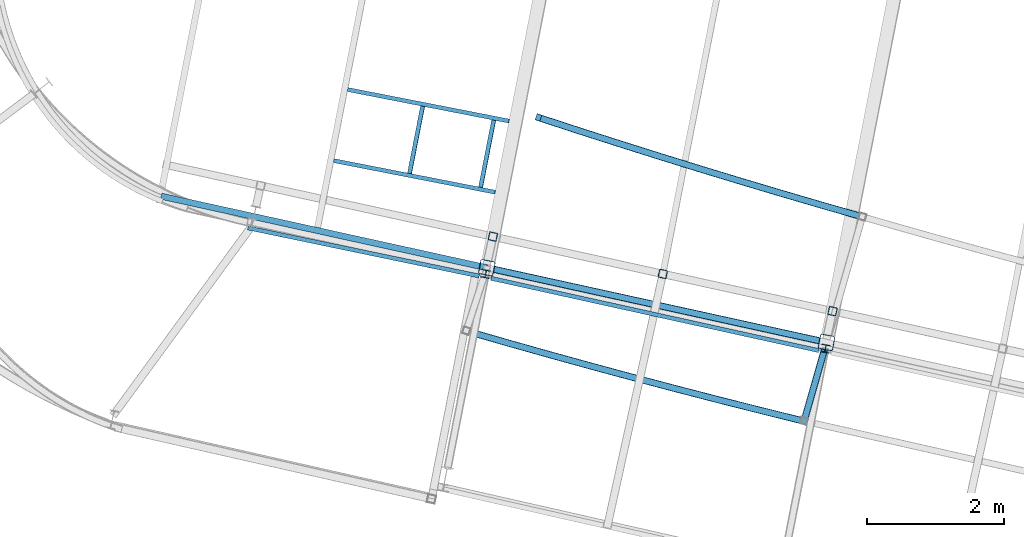
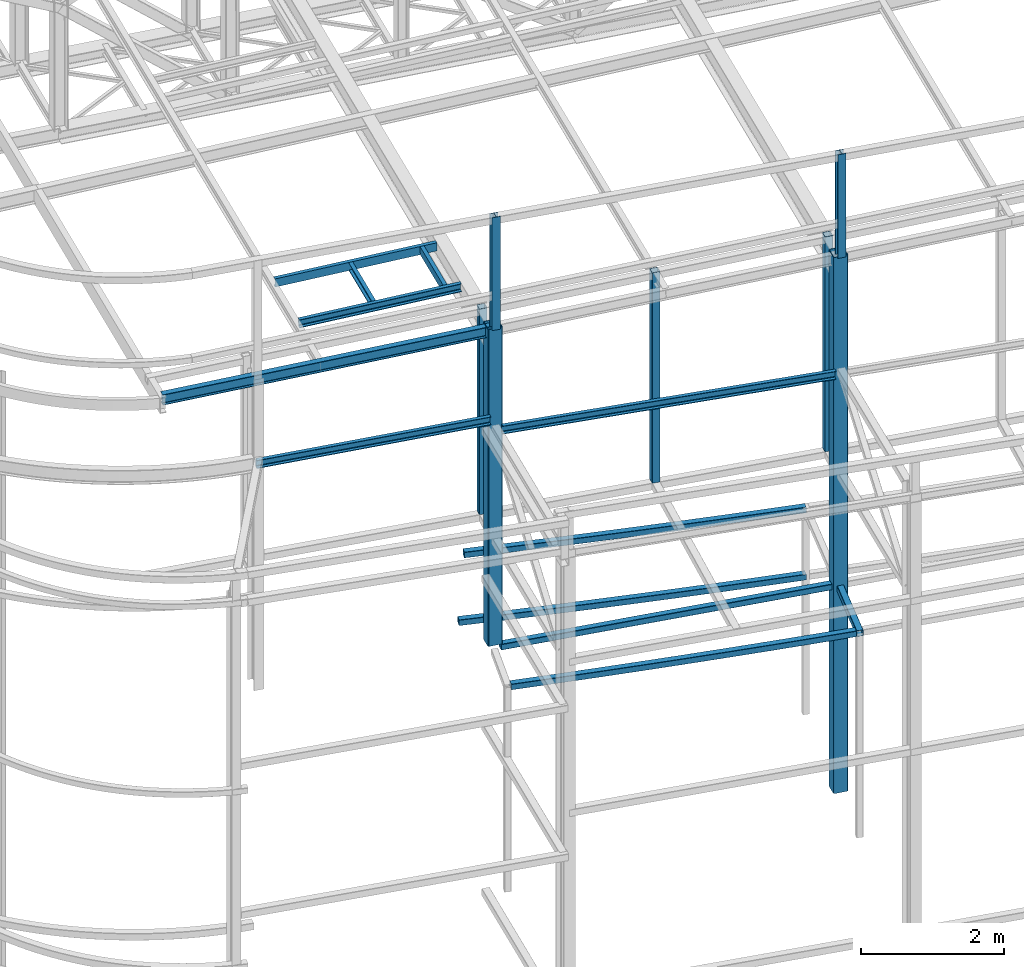
# One storey, part 22 of 215: 19 beams, 19 elements without a shape of their own.
"""IFC2X3 building model written with IfcOpenShell, lengths in millimetres."""

from ifc_helpers import new_model, entity, si_unit, frame, origin_with_axes, origin_2d_with_axis, place, context, subcontext, project, spatial, hollow_rectangle, i_section, u_section, extrude, clip, halfspace, material, type_object, element, aggregate, save


model = new_model("IFC2X3")

# Units and contexts
model_context = context("Model", 3, precision=1e-05, world=origin_with_axes())
body_context = subcontext(model_context, "Body", "Model", "MODEL_VIEW")
ifc_project = project(units=[si_unit("LENGTHUNIT", "METRE", prefix="MILLI"), si_unit("AREAUNIT", "SQUARE_METRE"), si_unit("VOLUMEUNIT", "CUBIC_METRE"), si_unit("MASSUNIT", "GRAM", prefix="KILO"), si_unit("TIMEUNIT", "SECOND"), si_unit("PLANEANGLEUNIT", "RADIAN"), si_unit("SOLIDANGLEUNIT", "STERADIAN"), si_unit("THERMODYNAMICTEMPERATUREUNIT", "DEGREE_CELSIUS"), si_unit("LUMINOUSINTENSITYUNIT", "LUMEN")], contexts=[model_context])

# Site, building, storey
site_placement = place(None, origin_with_axes())
site = spatial("IfcSite", under=ifc_project, at=site_placement, CompositionType="ELEMENT")
building_placement = place(site_placement, origin_with_axes())
building = spatial("IfcBuilding", under=site, at=building_placement, Name="Undefined", CompositionType="ELEMENT")
storey_placement = place(building_placement, origin_with_axes())
storey = spatial("IfcBuildingStorey", under=building, at=storey_placement, Name="Undefined", CompositionType="ELEMENT", Elevation=0.0)

# Assembly, beam
assembly_1_placement = place(storey_placement, origin_with_axes())
assembly_1 = element("IfcElementAssembly", 1, at=assembly_1_placement, inside=storey, Name="Steel Assembly", AssemblyPlace="NOTDEFINED", PredefinedType="RIGID_FRAME")
ifc_material_1 = material(Name="STEEL/S275JR")
beam_type_1 = type_object("IfcBeamType", PredefinedType="NOTDEFINED")
beam_1_placement = place(assembly_1_placement, frame((45837.825525202, 12378.7198330158, 6760.00000162277), z_axis=(0.29299903888334, 0.956112735619309, 0.0), x_axis=(0.95611273561931, -0.292999038883338, 0.0)))
beam_1 = element("IfcBeam", 2, at=beam_1_placement, type_object=beam_type_1, material=ifc_material_1, Name="POUTRE", context=body_context, shape_type="SweptSolid", body=[
    entity("IfcRevolvedAreaSolid", entity("IfcRectangleHollowProfileDef", "AREA", None, entity("IfcAxis2Placement2D", entity("IfcCartesianPoint", [0.0, 0.0]), entity("IfcDirection", [1.0, 0.0])), 100.0, 100.0, 4.0, 4.0, 8.0), entity("IfcAxis2Placement3D", entity("IfcCartesianPoint", [4921.58542662257, 0.0, 0.0]), entity("IfcDirection", [-0.999789717446947, 0.0, -0.0205066059442607]), entity("IfcDirection", [-6.93889390390723e-18, -1.0, -3.46944695195361e-18])), entity("IfcAxis1Placement", entity("IfcCartesianPoint", [0.0, 120000.0, 0.0]), entity("IfcDirection", [-1.0, 0.0, 0.0])), 0.0410160869179871),
])
aggregate(assembly_1, [beam_1])

assembly_2_placement = place(storey_placement, origin_with_axes())
assembly_2 = element("IfcElementAssembly", 3, at=assembly_2_placement, inside=storey, Name="Steel Assembly", AssemblyPlace="NOTDEFINED", PredefinedType="RIGID_FRAME")
beam_2_placement = place(assembly_2_placement, frame((45766.6930924765, 12402.1489431756, 5610.00000147687), z_axis=(0.293297378058425, 0.956021259190429, 0.0), x_axis=(0.95602125919043, -0.293297378058422, 0.0)))
beam_2 = element("IfcBeam", 4, at=beam_2_placement, type_object=beam_type_1, material=ifc_material_1, Name="POUTRE", context=body_context, shape_type="SweptSolid", body=[
    entity("IfcRevolvedAreaSolid", entity("IfcRectangleHollowProfileDef", "AREA", None, entity("IfcAxis2Placement2D", entity("IfcCartesianPoint", [0.0, 0.0]), entity("IfcDirection", [1.0, 0.0])), 100.0, 100.0, 4.0, 4.0, 8.0), entity("IfcAxis2Placement3D", entity("IfcCartesianPoint", [4996.46100115573, 0.0, 2.77359302256237e-13]), entity("IfcDirection", [-0.999783269721145, 0.0, -0.0208185875048156]), entity("IfcDirection", [-6.93889390390723e-18, -1.0, -3.46944695195361e-18])), entity("IfcAxis1Placement", entity("IfcCartesianPoint", [0.0, 120000.0, 0.0]), entity("IfcDirection", [-1.0, 0.0, 0.0])), 0.0416401832826093),
])
aggregate(assembly_2, [beam_2])

assembly_3_placement = place(storey_placement, origin_with_axes())
assembly_3 = element("IfcElementAssembly", 5, at=assembly_3_placement, inside=storey, Name="Steel Assembly", AssemblyPlace="NOTDEFINED", PredefinedType="RIGID_FRAME")
beam_3_placement = place(assembly_3_placement, frame((45047.8723003573, 10191.9760411381, 6760.00000147687), z_axis=(0.214484663892396, 0.976727356509976, 0.0), x_axis=(0.976727356509977, -0.214484663892393, 0.0)))
beam_3 = element("IfcBeam", 6, at=beam_3_placement, type_object=beam_type_1, material=ifc_material_1, Name="POUTRE", context=body_context, shape_type="Clipping", body=[
    clip(clip(extrude(hollow_rectangle(XDim=100.0, YDim=100.0, WallThickness=4.0, InnerFilletRadius=4.0, OuterFilletRadius=8.0, at=origin_2d_with_axis()), frame((5018.47853808158, 9.09494701772928e-13, 0.0), z_axis=(-1.0, 0.0, 0.0), x_axis=(-6.93889390390723e-18, -1.0, -3.46944695195361e-18)), (0.0, 0.0, 1.0), 4948.6), halfspace(frame((4979.20262696485, -49.9999999999991, -39.8982814427582), z_axis=(0.999733029085594, 0.0, 0.0231056390377605), x_axis=(-6.93889390390723e-18, -1.0, -3.46944695195361e-18)), False)), halfspace(frame((109.970634594116, -49.9999999999991, 2.5415534799431), z_axis=(0.999733029085594, 0.0, 0.0231056390377605), x_axis=(-6.93889390390723e-18, -1.0, -3.46944695195361e-18)), True)),
])
aggregate(assembly_3, [beam_3])

assembly_4_placement = place(storey_placement, origin_with_axes())
assembly_4 = element("IfcElementAssembly", 7, at=assembly_4_placement, inside=storey, Name="Steel Assembly", AssemblyPlace="NOTDEFINED", PredefinedType="RIGID_FRAME")
beam_4_placement = place(assembly_4_placement, frame((44793.7136169406, 9253.88664681881, 6760.00000147687), z_axis=(0.257990224984036, 0.966147526940211, 0.0), x_axis=(0.966147526940212, -0.257990224984035, 0.0)))
beam_4 = element("IfcBeam", 8, at=beam_4_placement, type_object=beam_type_1, material=ifc_material_1, Name="POUTRE", context=body_context, shape_type="SweptSolid", body=[
    entity("IfcRevolvedAreaSolid", entity("IfcRectangleHollowProfileDef", "AREA", None, entity("IfcAxis2Placement2D", entity("IfcCartesianPoint", [0.0, 0.0]), entity("IfcDirection", [1.0, 0.0])), 100.0, 100.0, 4.0, 4.0, 8.0), entity("IfcAxis2Placement3D", entity("IfcCartesianPoint", [5013.33512356359, 0.0, 0.0]), entity("IfcDirection", [-0.999781621235511, 0.0, -0.0208976036830495]), entity("IfcDirection", [-6.93889390390723e-18, -1.0, -3.46944695195361e-18])), entity("IfcAxis1Placement", entity("IfcCartesianPoint", [0.0, 119950.0, 0.0]), entity("IfcDirection", [-1.0, 0.0, 0.0])), 0.0417982500271299),
])
aggregate(assembly_4, [beam_4])

assembly_5_placement = place(storey_placement, origin_with_axes())
assembly_5 = element("IfcElementAssembly", 9, at=assembly_5_placement, inside=storey, Name="Steel Assembly", AssemblyPlace="NOTDEFINED", PredefinedType="RIGID_FRAME")
beam_5_placement = place(assembly_5_placement, frame((49675.0569423815, 7903.54776581965, 6760.00000147687), z_axis=(-0.961377854576722, 0.27523193987882, 0.0), x_axis=(0.275232267904521, 0.9613777606665, 0.0)))
beam_5 = element("IfcBeam", 10, at=beam_5_placement, type_object=beam_type_1, material=ifc_material_1, Name="POUTRE", context=body_context, shape_type="Clipping", body=[
    clip(extrude(hollow_rectangle(XDim=100.0, YDim=100.0, WallThickness=4.0, InnerFilletRadius=4.0, OuterFilletRadius=8.0, at=origin_2d_with_axis()), frame((1184.5171795672, 0.0, 0.0), z_axis=(-1.0, 0.0, 0.0), x_axis=(-6.93889390390723e-18, -1.0, -3.46944695195361e-18)), (0.0, 0.0, 1.0), 1184.5), halfspace(frame((1132.72084728135, -50.0, 23.6212822969828), z_axis=(-0.996323592676637, 0.0, -0.0856697068742402), x_axis=(-6.93889390390723e-18, -1.0, -3.46944695195361e-18)), True)),
])
aggregate(assembly_5, [beam_5])

assembly_6_placement = place(storey_placement, origin_with_axes())
assembly_6 = element("IfcElementAssembly", 11, at=assembly_6_placement, inside=storey, Name="Steel Assembly", AssemblyPlace="NOTDEFINED", PredefinedType="RIGID_FRAME")
beam_type_2 = type_object("IfcBeamType", PredefinedType="NOTDEFINED")
beam_6_placement = place(assembly_6_placement, frame((45136.7511241228, 10647.9751543151, 12286.9633996604), z_axis=(-0.214538758981639, -0.97671547591641, 0.0), x_axis=(0.0, 0.0, -1.0)))
beam_6 = element("IfcBeam", 12, at=beam_6_placement, type_object=beam_type_2, material=ifc_material_1, Name="LISSE", context=body_context, shape_type="SweptSolid", body=[
    extrude(hollow_rectangle(XDim=120.0, YDim=120.0, WallThickness=5.0, InnerFilletRadius=5.0, OuterFilletRadius=10.0, at=origin_2d_with_axis()), frame((3520.96259080933, 0.0, 3.63797881091433e-12), z_axis=(-1.0, 0.0, 0.0), x_axis=(-6.93889390390723e-18, -1.0, -3.46944695195361e-18)), (0.0, 0.0, 1.0), 3521.0),
])
aggregate(assembly_6, [beam_6])

assembly_7_placement = place(storey_placement, origin_with_axes())
assembly_7 = element("IfcElementAssembly", 13, at=assembly_7_placement, inside=storey, Name="Steel Assembly", AssemblyPlace="NOTDEFINED", PredefinedType="RIGID_FRAME")
beam_7_placement = place(assembly_7_placement, frame((47622.3901824429, 10101.9955824425, 12367.8997714332), z_axis=(-0.214538758981639, -0.97671547591641, 0.0), x_axis=(0.0, 0.0, -1.0)))
beam_7 = element("IfcBeam", 14, at=beam_7_placement, type_object=beam_type_2, material=ifc_material_1, Name="LISSE", context=body_context, shape_type="SweptSolid", body=[
    extrude(hollow_rectangle(XDim=120.0, YDim=120.0, WallThickness=5.0, InnerFilletRadius=5.0, OuterFilletRadius=10.0, at=origin_2d_with_axis()), frame((3601.89896264097, -2.38353679221718e-20, -3.6379788002018e-12), z_axis=(-1.0, 0.0, 0.0), x_axis=(-6.93889390390723e-18, -1.0, -3.46944695195361e-18)), (0.0, 0.0, 1.0), 3601.9),
])
aggregate(assembly_7, [beam_7])

assembly_8_placement = place(storey_placement, origin_with_axes())
assembly_8 = element("IfcElementAssembly", 15, at=assembly_8_placement, inside=storey, Name="Steel Assembly", AssemblyPlace="NOTDEFINED", PredefinedType="RIGID_FRAME")
beam_8_placement = place(assembly_8_placement, frame((50105.8417070042, 9556.49651023905, 12447.0923641083), z_axis=(-0.214538758981639, -0.97671547591641, 0.0), x_axis=(0.0, 0.0, -1.0)))
beam_8 = element("IfcBeam", 16, at=beam_8_placement, type_object=beam_type_2, material=ifc_material_1, Name="LISSE", context=body_context, shape_type="SweptSolid", body=[
    extrude(hollow_rectangle(XDim=120.0, YDim=120.0, WallThickness=5.0, InnerFilletRadius=5.0, OuterFilletRadius=10.0, at=origin_2d_with_axis()), frame((3681.09155535645, 2.43594205409882e-20, -3.6379788091851e-12), z_axis=(-1.0, 0.0, 0.0), x_axis=(-6.93889390390723e-18, -1.0, -3.46944695195361e-18)), (0.0, 0.0, 1.0), 3681.1),
])
aggregate(assembly_8, [beam_8])

assembly_9_placement = place(storey_placement, origin_with_axes())
assembly_9 = element("IfcElementAssembly", 17, at=assembly_9_placement, inside=storey, Name="Steel Assembly", AssemblyPlace="NOTDEFINED", PredefinedType="RIGID_FRAME")
ifc_material_2 = material(Name="STEEL/S235JR")
beam_type_3 = type_object("IfcBeamType", Name="UPN140", PredefinedType="NOTDEFINED")
beam_9_placement = place(assembly_9_placement, frame((44109.917209963, 12554.1309467955, 12176.4570612579), z_axis=(-0.0304080349967745, 0.00594450299936818, 0.999519891893966), x_axis=(-0.191830712949918, -0.981428029743786, 1.53499999873056e-06)))
beam_9 = element("IfcBeam", 18, at=beam_9_placement, type_object=beam_type_3, material=ifc_material_2, ObjectType="UPN140", context=body_context, shape_type="SweptSolid", body=[
    extrude(u_section(Depth=140.0, FlangeWidth=60.0, WebThickness=7.0, FlangeThickness=10.0, FilletRadius=10.0, EdgeRadius=5.0, FlangeSlope=0.0798299857122373, at=origin_2d_with_axis()), frame((1000.02653755024, 4.45927034623156e-15, 2.52634280635597e-16), z_axis=(-1.0, 0.0, 0.0), x_axis=(-6.93889390390723e-18, -1.0, -3.46944695195361e-18)), (0.0, 0.0, 1.0), 1000.0),
])
aggregate(assembly_9, [beam_9])

assembly_10_placement = place(storey_placement, origin_with_axes())
assembly_10 = element("IfcElementAssembly", 19, at=assembly_10_placement, inside=storey, Name="Steel Assembly", AssemblyPlace="NOTDEFINED", PredefinedType="RIGID_FRAME")
beam_10_placement = place(assembly_10_placement, frame((45372.7606796322, 12337.8396466009, 12216.1624909188), z_axis=(-0.0304080349967745, 0.00594450299936818, 0.999519891893966), x_axis=(-0.980955161801974, 0.191747187961292, -0.0309836479937451)))
beam_10 = element("IfcBeam", 20, at=beam_10_placement, type_object=beam_type_3, material=ifc_material_2, ObjectType="UPN140", context=body_context, shape_type="SweptSolid", body=[
    extrude(u_section(Depth=140.0, FlangeWidth=60.0, WebThickness=7.0, FlangeThickness=10.0, FilletRadius=10.0, EdgeRadius=5.0, FlangeSlope=0.0798299857122373, at=origin_2d_with_axis()), frame((2404.26547487024, -4.76208710676447e-14, 1.81898940354586e-12), z_axis=(-1.0, 0.0, 0.0), x_axis=(-6.93889390390723e-18, -1.0, -3.46944695195361e-18)), (0.0, 0.0, 1.0), 2404.3),
])
aggregate(assembly_10, [beam_10])

assembly_11_placement = place(storey_placement, origin_with_axes())
assembly_11 = element("IfcElementAssembly", 21, at=assembly_11_placement, inside=storey, Name="Steel Assembly", AssemblyPlace="NOTDEFINED", PredefinedType="RIGID_FRAME")
beam_11_placement = place(assembly_11_placement, frame((44957.8907575464, 11369.4272011601, 12209.3011539146), z_axis=(-0.0304080349967745, 0.00594450299936818, 0.999519891893966), x_axis=(0.191844712070631, 0.981425293361314, -1.0930000008509e-06)))
beam_11 = element("IfcBeam", 22, at=beam_11_placement, type_object=beam_type_3, material=ifc_material_2, ObjectType="UPN140", context=body_context, shape_type="SweptSolid", body=[
    extrude(u_section(Depth=140.0, FlangeWidth=60.0, WebThickness=7.0, FlangeThickness=10.0, FilletRadius=10.0, EdgeRadius=5.0, FlangeSlope=0.0798299857122373, at=origin_2d_with_axis()), frame((1000.02653755024, 4.45927034623156e-15, 2.52634280635597e-16), z_axis=(-1.0, 0.0, 0.0), x_axis=(-6.93889390390723e-18, -1.0, -3.46944695195361e-18)), (0.0, 0.0, 1.0), 1000.0),
])
aggregate(assembly_11, [beam_11])

assembly_12_placement = place(storey_placement, origin_with_axes())
assembly_12 = element("IfcElementAssembly", 23, at=assembly_12_placement, inside=storey, Name="Steel Assembly", AssemblyPlace="NOTDEFINED", PredefinedType="RIGID_FRAME")
beam_12_placement = place(assembly_12_placement, frame((42810.9281780247, 11758.6209269209, 12141.670201215), z_axis=(-0.0304080349967745, 0.00594450299936818, 0.999519891893966), x_axis=(0.9809472788136, -0.191787511963556, 0.0309836479941128)))
beam_12 = element("IfcBeam", 24, at=beam_12_placement, type_object=beam_type_3, material=ifc_material_2, ObjectType="UPN140", context=body_context, shape_type="SweptSolid", body=[
    extrude(u_section(Depth=140.0, FlangeWidth=60.0, WebThickness=7.0, FlangeThickness=10.0, FilletRadius=10.0, EdgeRadius=5.0, FlangeSlope=0.0798299857122373, at=origin_2d_with_axis()), frame((2404.26547487024, -4.76208710676447e-14, 1.81898940354586e-12), z_axis=(-1.0, 0.0, 0.0), x_axis=(-6.93889390390723e-18, -1.0, -3.46944695195361e-18)), (0.0, 0.0, 1.0), 2404.3),
])
aggregate(assembly_12, [beam_12])

assembly_13_placement = place(storey_placement, origin_with_axes())
assembly_13 = element("IfcElementAssembly", 25, at=assembly_13_placement, inside=storey, Name="Steel Assembly", AssemblyPlace="NOTDEFINED", PredefinedType="RIGID_FRAME")
beam_13_placement = place(assembly_13_placement, frame((44937.2509258051, 10070.757264333, 10760.8089710771), z_axis=(-0.00270083499983902, 8.71699999953952e-05, -0.999996348939182), x_axis=(-0.9790331913176, 0.203683392066075, 0.00266197200086367)))
beam_13 = element("IfcBeam", 26, at=beam_13_placement, type_object=beam_type_3, material=ifc_material_1, ObjectType="UPN140", context=body_context, shape_type="SweptSolid", body=[
    extrude(u_section(Depth=140.0, FlangeWidth=60.0, WebThickness=7.0, FlangeThickness=10.0, FilletRadius=10.0, EdgeRadius=5.0, FlangeSlope=0.0798299857122373, at=origin_2d_with_axis()), frame((3457.25495268888, -3.38850838909327e-12, 1.82048874887807e-12), z_axis=(-1.0, 0.0, 0.0), x_axis=(-6.93889390390723e-18, -1.0, -3.46944695195361e-18)), (0.0, 0.0, 1.0), 3457.3),
])
aggregate(assembly_13, [beam_13])

assembly_14_placement = place(storey_placement, origin_with_axes())
assembly_14 = element("IfcElementAssembly", 27, at=assembly_14_placement, inside=storey, Name="Steel Assembly", AssemblyPlace="NOTDEFINED", PredefinedType="RIGID_FRAME")
beam_14_placement = place(assembly_14_placement, frame((49900.446993969, 8980.9453078275, 10463.761096539), z_axis=(-0.0195417610019211, 0.00430897700042411, -0.999799756098267), x_axis=(-0.976346150992971, 0.21528526599845, 0.0200111889998559)))
beam_14 = element("IfcBeam", 28, at=beam_14_placement, type_object=beam_type_3, material=ifc_material_1, ObjectType="UPN140", context=body_context, shape_type="SweptSolid", body=[
    extrude(u_section(Depth=140.0, FlangeWidth=60.0, WebThickness=7.0, FlangeThickness=10.0, FilletRadius=10.0, EdgeRadius=5.0, FlangeSlope=0.0798299857122373, at=origin_2d_with_axis()), frame((4905.81166693343, -3.46962462116058e-12, 0.0), z_axis=(-1.0, 0.0, 0.0), x_axis=(-6.93889390390723e-18, -1.0, -3.46944695195361e-18)), (0.0, 0.0, 1.0), 4905.8),
])
aggregate(assembly_14, [beam_14])

assembly_15_placement = place(storey_placement, origin_with_axes())
assembly_15 = element("IfcElementAssembly", 29, at=assembly_15_placement, inside=storey, Name="Steel Assembly", AssemblyPlace="NOTDEFINED", PredefinedType="RIGID_FRAME")
beam_type_4 = type_object("IfcBeamType", Name="IPE180", PredefinedType="NOTDEFINED")
beam_15_placement = place(assembly_15_placement, frame((40287.803499588, 11238.2200148801, 12047.4817455715), z_axis=(0.0302611110139303, -0.00664964300306178, -0.999519908460124), x_axis=(0.976227964397354, -0.214520416087316, 0.030983102012611)))
beam_15 = element("IfcBeam", 30, at=beam_15_placement, type_object=beam_type_4, material=ifc_material_1, Name="POUTRE", ObjectType="IPE180", context=body_context, shape_type="SweptSolid", body=[
    extrude(i_section(OverallWidth=91.0, OverallDepth=180.0, WebThickness=5.300000191, FlangeThickness=8.0, FilletRadius=9.0, at=origin_2d_with_axis()), frame((4875.53621245488, 1.25058495861707e-13, 0.0), z_axis=(-1.0, 0.0, 0.0), x_axis=(-6.93889390390723e-18, -1.0, -3.46944695195361e-18)), (0.0, 0.0, 1.0), 4875.5),
])
aggregate(assembly_15, [beam_15])

assembly_16_placement = place(storey_placement, origin_with_axes())
assembly_16 = element("IfcElementAssembly", 31, at=assembly_16_placement, inside=storey, Name="Steel Assembly", AssemblyPlace="NOTDEFINED", PredefinedType="RIGID_FRAME")
beam_type_5 = type_object("IfcBeamType", Name="HEA120", PredefinedType="NOTDEFINED")
beam_16_placement = place(assembly_16_placement, frame((45030.1096803262, 10101.114552555, 14219.9969912719), z_axis=(0.191859470081235, 0.981422408415534, 0.0), x_axis=(0.0, 0.0, -1.0)))
beam_16 = element("IfcBeam", 32, at=beam_16_placement, type_object=beam_type_5, material=ifc_material_1, ObjectType="HEA120", context=body_context, shape_type="SweptSolid", body=[
    extrude(i_section(OverallWidth=120.0, OverallDepth=114.0, WebThickness=5.0, FlangeThickness=8.0, FilletRadius=12.0, at=origin_2d_with_axis()), frame((1933.03359527425, 7.27595761418343e-12, 0.0), z_axis=(-1.0, 0.0, 0.0), x_axis=(-6.93889390390723e-18, -1.0, -3.46944695195361e-18)), (0.0, 0.0, 1.0), 1933.0),
])
aggregate(assembly_16, [beam_16])

assembly_17_placement = place(storey_placement, origin_with_axes())
assembly_17 = element("IfcElementAssembly", 33, at=assembly_17_placement, inside=storey, Name="Steel Assembly", AssemblyPlace="NOTDEFINED", PredefinedType="RIGID_FRAME")
beam_17_placement = place(assembly_17_placement, frame((50000.0221952321, 9009.85731332752, 14219.9969920042), z_axis=(0.191859470081235, 0.981422408415534, 0.0), x_axis=(0.0, 0.0, -1.0)))
beam_17 = element("IfcBeam", 34, at=beam_17_placement, type_object=beam_type_5, material=ifc_material_1, ObjectType="HEA120", context=body_context, shape_type="SweptSolid", body=[
    extrude(i_section(OverallWidth=120.0, OverallDepth=114.0, WebThickness=5.0, FlangeThickness=8.0, FilletRadius=12.0, at=origin_2d_with_axis()), frame((1775.34565740461, 0.0, 0.0), z_axis=(-1.0, 0.0, 0.0), x_axis=(-6.93889390390723e-18, -1.0, -3.46944695195361e-18)), (0.0, 0.0, 1.0), 1775.3),
])
aggregate(assembly_17, [beam_17])

assembly_18_placement = place(storey_placement, origin_with_axes())
assembly_18 = element("IfcElementAssembly", 35, at=assembly_18_placement, inside=storey, Name="Steel Assembly", AssemblyPlace="NOTDEFINED", PredefinedType="RIGID_FRAME")
beam_type_6 = type_object("IfcBeamType", PredefinedType="NOTDEFINED")
beam_18_placement = place(assembly_18_placement, frame((45047.8723003359, 10191.9760412474, 12286.963395907), z_axis=(0.191859470081235, 0.981422408415534, 0.0), x_axis=(0.0, 0.0, -1.0)))
beam_18 = element("IfcBeam", 36, at=beam_18_placement, type_object=beam_type_6, material=ifc_material_1, Name="POTEAU", context=body_context, shape_type="SweptSolid", body=[
    extrude(hollow_rectangle(XDim=220.0, YDim=220.0, WallThickness=10.0, InnerFilletRadius=15.0, OuterFilletRadius=25.0, at=origin_2d_with_axis()), frame((5426.96277974255, 2.8056739977812e-22, 1.12226959911248e-21), z_axis=(-1.0, 0.0, 0.0), x_axis=(-6.93889390390723e-18, -1.0, -3.46944695195361e-18)), (0.0, 0.0, 1.0), 5427.0),
])
aggregate(assembly_18, [beam_18])

assembly_19_placement = place(storey_placement, origin_with_axes())
assembly_19 = element("IfcElementAssembly", 37, at=assembly_19_placement, inside=storey, Name="Steel Assembly", AssemblyPlace="NOTDEFINED", PredefinedType="RIGID_FRAME")
beam_19_placement = place(assembly_19_placement, frame((50017.7644908896, 9100.61483474182, 12444.6513345088), z_axis=(0.191859470081235, 0.981422408415534, 0.0), x_axis=(0.0, 0.0, -1.0)))
beam_19 = element("IfcBeam", 38, at=beam_19_placement, type_object=beam_type_6, material=ifc_material_1, Name="POTEAU", context=body_context, shape_type="SweptSolid", body=[
    extrude(hollow_rectangle(XDim=220.0, YDim=220.0, WallThickness=10.0, InnerFilletRadius=15.0, OuterFilletRadius=25.0, at=origin_2d_with_axis()), frame((9184.65342463352, -4.74835452867226e-22, -1.8993418114689e-21), z_axis=(-1.0, 0.0, 0.0), x_axis=(-6.93889390390723e-18, -1.0, -3.46944695195361e-18)), (0.0, 0.0, 1.0), 9184.7),
])
aggregate(assembly_19, [beam_19])

save(model, "model.ifc")
